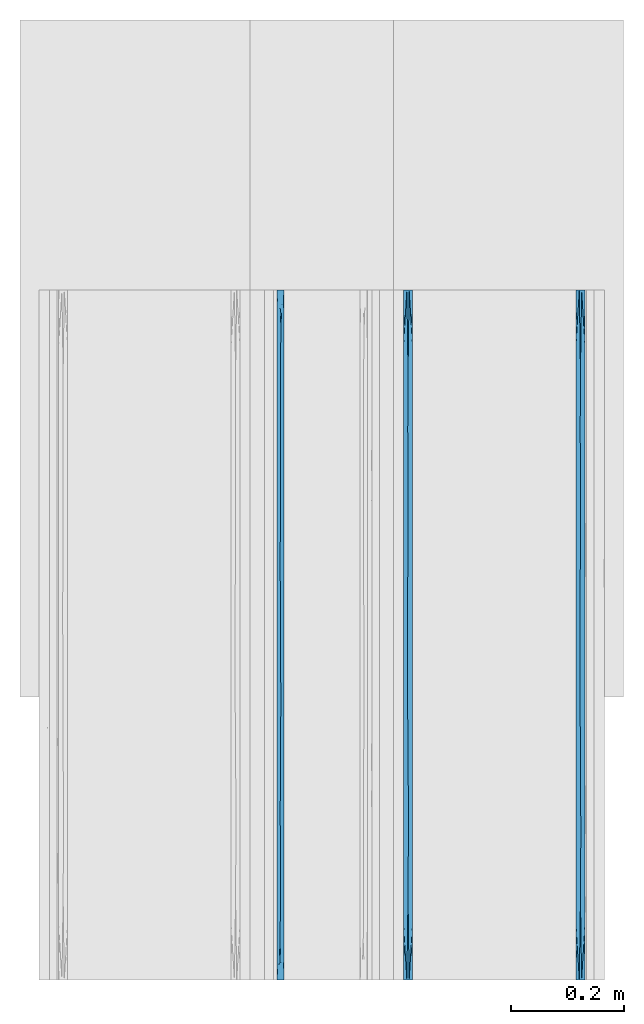
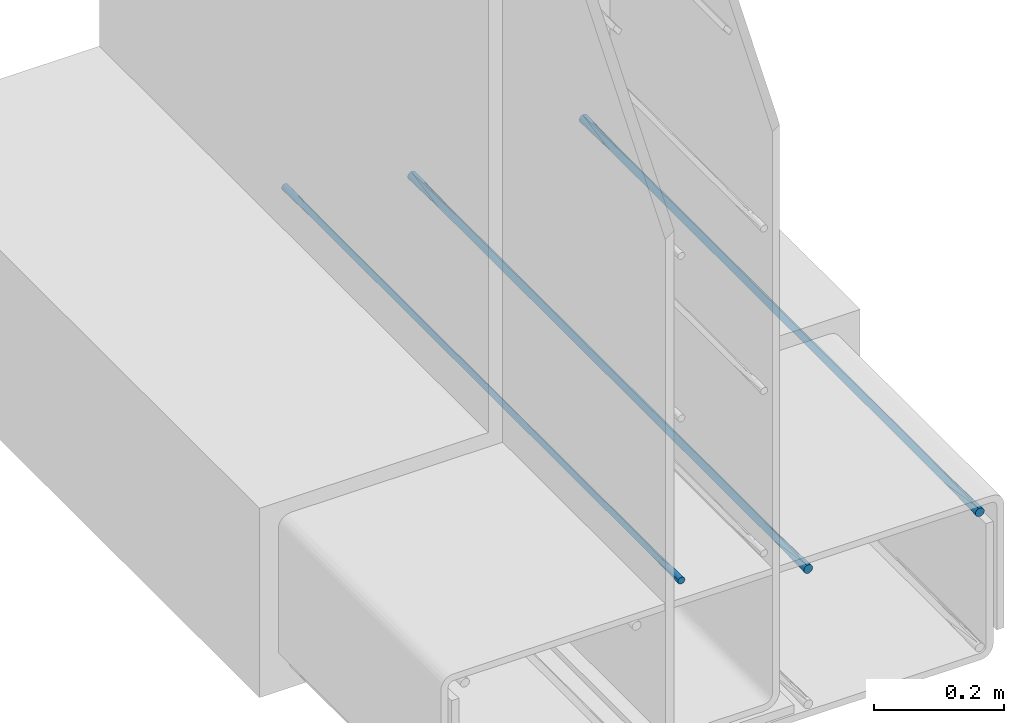
# One storey, part 7 of 10: 3 walls.
"""IFC2X3 building model written with IfcOpenShell, lengths in feet."""

from ifc_helpers import new_model, entity, si_unit, converted_unit, derived_unit, direction, frame, origin, place, context, subcontext, project, spatial, faceted_brep, material, type_object, element, save


model = new_model("IFC2X3")

# Units and contexts
model_context = context("Model", 3, precision=0.0001, world=origin(), true_north=direction((6.12303176911189e-17, 1.0)))
body_context = subcontext(model_context, "Body", "Model", "MODEL_VIEW")
ifc_project = project(units=[converted_unit("LENGTHUNIT", "FOOT", entity("IfcRatioMeasure", 0.3048), si_unit("LENGTHUNIT", "METRE"), dimensions=[1, 0, 0, 0, 0, 0, 0]), converted_unit("AREAUNIT", "SQUARE FOOT", entity("IfcRatioMeasure", 0.09290304), si_unit("AREAUNIT", "SQUARE_METRE"), dimensions=[2, 0, 0, 0, 0, 0, 0]), converted_unit("VOLUMEUNIT", "CUBIC FOOT", entity("IfcRatioMeasure", 0.028316846592), si_unit("VOLUMEUNIT", "CUBIC_METRE"), dimensions=[3, 0, 0, 0, 0, 0, 0]), converted_unit("PLANEANGLEUNIT", "DEGREE", entity("IfcRatioMeasure", 0.0174532925199433), si_unit("PLANEANGLEUNIT", "RADIAN"), dimensions=[0, 0, 0, 0, 0, 0, 0]), si_unit("MASSUNIT", "GRAM", prefix="KILO"), derived_unit("MASSDENSITYUNIT", [(si_unit("MASSUNIT", "GRAM", prefix="KILO"), 1), (si_unit("LENGTHUNIT", "METRE"), -3)]), si_unit("TIMEUNIT", "SECOND"), si_unit("FREQUENCYUNIT", "HERTZ"), si_unit("THERMODYNAMICTEMPERATUREUNIT", "DEGREE_CELSIUS"), derived_unit("THERMALTRANSMITTANCEUNIT", [(si_unit("MASSUNIT", "GRAM", prefix="KILO"), 1), (si_unit("THERMODYNAMICTEMPERATUREUNIT", "KELVIN"), -1), (si_unit("TIMEUNIT", "SECOND"), -3)]), derived_unit("VOLUMETRICFLOWRATEUNIT", [(si_unit("LENGTHUNIT", "METRE"), 3), (si_unit("TIMEUNIT", "SECOND"), -1)]), si_unit("ELECTRICCURRENTUNIT", "AMPERE"), si_unit("ELECTRICVOLTAGEUNIT", "VOLT"), si_unit("POWERUNIT", "WATT"), si_unit("FORCEUNIT", "NEWTON", prefix="KILO"), si_unit("ILLUMINANCEUNIT", "LUX"), si_unit("LUMINOUSFLUXUNIT", "LUMEN"), si_unit("LUMINOUSINTENSITYUNIT", "CANDELA"), derived_unit("USERDEFINED", [(si_unit("MASSUNIT", "GRAM", prefix="KILO"), -1), (si_unit("LENGTHUNIT", "METRE"), -2), (si_unit("TIMEUNIT", "SECOND"), 3), (si_unit("LUMINOUSFLUXUNIT", "LUMEN"), 1)]), derived_unit("LINEARVELOCITYUNIT", [(si_unit("LENGTHUNIT", "METRE"), 1), (si_unit("TIMEUNIT", "SECOND"), -1)]), si_unit("PRESSUREUNIT", "PASCAL"), derived_unit("USERDEFINED", [(si_unit("LENGTHUNIT", "METRE"), -2), (si_unit("MASSUNIT", "GRAM", prefix="KILO"), 1), (si_unit("TIMEUNIT", "SECOND"), -2)])], contexts=[model_context])

# Site, building, storey
site_placement = place(None, origin())
site = spatial("IfcSite", under=ifc_project, at=site_placement, CompositionType="ELEMENT")
building_placement = place(site_placement, origin())
building = spatial("IfcBuilding", under=site, at=building_placement, CompositionType="ELEMENT")
storey_placement = place(building_placement, frame((0.0, 0.0, 11.2604166666667)))
storey = spatial("IfcBuildingStorey", under=building, at=storey_placement, Name="2ND FLOOR", CompositionType="ELEMENT", Elevation=11.2604166666667)

# Walls
ifc_material_1 = material()
wall_type_1 = type_object("IfcWallType", Name="Generic Models 1", PredefinedType="NOTDEFINED", material=ifc_material_1)
wall_1_placement = place(storey_placement, frame((1430.15274703322, 0.249999999995827, 3.71232507741509), z_axis=(0.0, 0.0, 1.0), x_axis=(0.0, 1.0, 0.0)))
element("IfcWall", 1, at=wall_1_placement, inside=storey, type_object=wall_type_1, material=ifc_material_1, Name="Generic Models 83:Generic Models 1", ObjectType="Generic Models 83:Generic Models 1", context=body_context, shape_type="Brep", body=[
    faceted_brep([(4.0, -0.0130208333334849, 0.0034889217764551), (4.0, -0.00762742757342494, 0.0076274275732775), (4.0, -0.00348892177657945, 0.0130208333333464), (4.0, -0.000887348273863608, 0.0193015873671367), (4.0, 0.0, 0.0260416666666821), (4.0, -0.000887348273863608, 0.0327817459662274), (4.0, -0.00348892177657945, 0.0390625000000142), (4.0, -0.00762742757342494, 0.0444559057600777), (4.0, -0.0130208333334849, 0.0485944115568948), (4.0, -0.0193015873671811, 0.0511959850596142), (4.0, -0.0260416666667425, 0.0520833333333321), (4.0, -0.0327817459663038, 0.0511959850596071), (4.0, -0.0390625, 0.048594411556877), (4.0, -0.04445590576006, 0.0444559057600546), (4.0, -0.0485944115569055, 0.0390624999999858), (4.0, -0.0511959850596213, 0.0327817459661954), (4.0, -0.0520833333334849, 0.0260416666666501), (4.0, -0.0511959850596213, 0.0193015873671047), (4.0, -0.0485944115569055, 0.0130208333333179), (4.0, -0.04445590576006, 0.00762742757325441), (4.0, -0.0390625, 0.00348892177643734), (4.0, -0.0327817459663038, 0.000887348273717947), (4.0, -0.0260416666667425, 0.0), (4.0, -0.0193015873671811, 0.000887348273725053), (0.0, -0.0260416666667425, 0.0520833333333393), (0.0, -0.0193015873671811, 0.0511959850596213), (0.0, -0.0130208333334849, 0.0485944115569019), (0.0, -0.00762742757342494, 0.0444559057600848), (0.0, -0.00348892177657945, 0.0390625000000213), (0.0, -0.000887348273863608, 0.0327817459662345), (0.0, 0.0, 0.0260416666666892), (0.0, -0.000887348273863608, 0.0193015873671438), (0.0, -0.00348892177657945, 0.0130208333333535), (0.0, -0.00762742757342494, 0.00762742757328461), (0.0, -0.0130208333334849, 0.00348892177646221), (0.0, -0.0193015873671811, 0.000887348273732158), (0.0, -0.0260416666667425, 0.0), (0.0, -0.0327817459663038, 0.000887348273725053), (0.0, -0.0390625, 0.00348892177644444), (0.0, -0.04445590576006, 0.00762742757326151), (0.0, -0.0485944115569055, 0.013020833333325), (0.0, -0.0511959850596213, 0.0193015873671119), (0.0, -0.0520833333334849, 0.0260416666666572), (0.0, -0.0511959850596213, 0.0327817459662025), (0.0, -0.0485944115569055, 0.0390624999999929), (0.0, -0.04445590576006, 0.0444559057600618), (0.0, -0.0390625, 0.0485944115568842), (0.0, -0.0327817459663038, 0.0511959850596142), (3.67725138549306, 0.0, 0.0260416666666821), (0.32274862547415, -0.0520833333334849, 0.0260416666666572), (3.67725140296933, -0.0520833333334849, 0.0260416666666501), (3.51587705267192, -0.0260416670323593, 0.0), (2.87037982919681, -0.0260416666374113, 0.0), (2.52958652603254, -0.026227183774381, 6.60807051744428e-07), (2.70900554197223, 0.0, 0.0260416666666838), (2.70900552654688, -0.0520833333334849, 0.0260416666666536), (1.90213399266994, -0.0280271573828941, 7.58000453888741e-05), (1.5, 0.0, 0.0260416666666874), (1.74075971428411, 0.0, 0.0260416666666856), (2.0, 0.0, 0.0260416666666856), (1.58481828942483, -0.0281065462752395, 8.19926513742075e-05), (2.35450277098611, 0.0, 0.0260416666666838), (2.38625689346174, 0.0, 0.0260416666666874), (0.322748614506943, 0.0, 0.0260416666666892), (0.484122917594275, -0.0260416666644687, 0.0), (0.645497229013885, 0.0, 0.0260416666666874), (3.03175415647917, 0.0, 0.0260416666666838), (3.35450277098611, 0.0, 0.0260416666666838), (0.802626606099821, -0.0241210785507064, 7.09188132521632e-05), (1.0, 0.0, 0.0260416666666874), (1.12499999124347, -0.0246126796300814, 3.92360336185504e-05), (3.35450277749518, -0.0520833333334849, 0.0260416666666519), (2.2160433903769, -0.0283845183157609, 0.000105602028249052), (2.06350830404206, -0.0520833333334849, 0.0260416666666536), (2.00000002040847, -0.0520833333334849, 0.0260416666666536), (1.74075970701139, -0.0520833333334849, 0.0260416666666536), (3.19312844079874, -0.0276322430397613, 4.86201045735157e-05), (3.03175415202103, -0.0520833333334849, 0.0260416666666519), (0.70900554076862, -0.0520833333334849, 0.0260416666666554), (0.645497257127644, -0.0520833333334849, 0.0260416666666554), (1.41801108153724, -0.0520833333334849, 0.0260416666666554), (1.25, 0.0, 0.0260416666666874), (1.41801107183056, 0.0, 0.0260416666666874), (2.38625690107273, -0.0520833333334849, 0.0260416666666519), (2.06350830387292, 0.0, 0.0260416666666856), (1.50000002551058, -0.0520833333334849, 0.0260416666666519), (1.25000002806164, -0.0520833333334849, 0.0260416666666554), (1.06350832537467, -0.0520833333334849, 0.0260416666666554), (1.06350827744056, 0.0, 0.0260416666666874), (1.0000000306127, -0.0520833333334849, 0.0260416666666554), (2.35450279389352, -0.0520833333334849, 0.0260416666666519), (0.70900553591528, 0.0, 0.0260416666666874), (1.90213399388276, -0.0240561759483171, 0.0520075332877745), (3.51587705385881, -0.0260416658200029, 0.0520833333333339), (2.87037983051048, -0.0260416667615573, 0.0520833333333339), (2.52958652644354, -0.0258561495911636, 0.0520826725265131), (0.484122917756005, -0.0260416666742458, 0.0520833333333393), (3.19312844116365, -0.0244510900004116, 0.0520347132108157), (1.58481829017475, -0.023976787102356, 0.0520013406854787), (1.12499999099503, -0.0274706537484235, 0.052044097297248), (0.802626606321884, -0.0279622548152929, 0.0520124145176908), (2.2160433912069, -0.023698814974523, 0.051977731301184)], [[[0, 1, 2, 3, 4, 5, 6, 7, 8, 9, 10, 11, 12, 13, 14, 15, 16, 17, 18, 19, 20, 21, 22, 23]], [[24, 25, 26, 27, 28, 29, 30, 31, 32, 33, 34, 35, 36, 37, 38, 39, 40, 41, 42, 43, 44, 45, 46, 47]], [[2, 48, 3]], [[49, 42, 41]], [[17, 16, 50]], [[20, 50, 21]], [[50, 51, 21]], [[40, 49, 41]], [[52, 53, 54]], [[52, 55, 53]], [[50, 19, 18]], [[56, 57, 58, 59]], [[38, 37, 49]], [[60, 57, 56]], [[0, 48, 1]], [[53, 61, 62, 54]], [[63, 32, 31]], [[64, 63, 65]], [[52, 54, 66]], [[48, 51, 67]], [[68, 69, 70]], [[23, 22, 51]], [[35, 64, 36]], [[2, 1, 48]], [[18, 17, 50]], [[19, 50, 20]], [[50, 71, 51]], [[56, 72, 73]], [[56, 73, 74, 75]], [[67, 51, 76]], [[55, 52, 77]], [[64, 78, 79, 49]], [[39, 38, 49]], [[0, 23, 48]], [[48, 23, 51]], [[60, 80, 70]], [[64, 65, 68]], [[37, 36, 64]], [[51, 22, 21]], [[60, 81, 82, 57]], [[40, 39, 49]], [[32, 63, 33]], [[77, 52, 76]], [[66, 67, 76]], [[34, 33, 63]], [[71, 77, 76]], [[35, 63, 64]], [[34, 63, 35]], [[48, 4, 3]], [[31, 30, 63]], [[53, 72, 61]], [[53, 83, 72]], [[64, 49, 37]], [[56, 75, 60]], [[72, 59, 84, 61]], [[60, 75, 85, 80]], [[70, 81, 60]], [[64, 68, 78]], [[70, 80, 86, 87]], [[70, 69, 88, 81]], [[68, 87, 89, 78]], [[72, 56, 59]], [[83, 53, 55]], [[72, 83, 90, 73]], [[76, 52, 66]], [[71, 76, 51]], [[68, 65, 91, 69]], [[87, 68, 70]], [[92, 84, 59, 58]], [[14, 50, 15]], [[8, 48, 9]], [[48, 93, 9]], [[28, 63, 29]], [[94, 95, 55]], [[44, 43, 49]], [[94, 54, 95]], [[47, 96, 24]], [[11, 10, 93]], [[5, 4, 48]], [[63, 30, 29]], [[66, 94, 97]], [[98, 85, 92]], [[12, 50, 13]], [[98, 86, 80, 85]], [[89, 99, 100]], [[49, 79, 96]], [[96, 91, 65, 63]], [[7, 48, 8]], [[48, 6, 5]], [[14, 13, 50]], [[48, 7, 6]], [[50, 93, 71]], [[48, 67, 93]], [[92, 101, 84]], [[12, 11, 50]], [[66, 54, 94]], [[95, 90, 83, 55]], [[27, 26, 63]], [[50, 11, 93]], [[96, 79, 100]], [[98, 82, 99]], [[92, 85, 75, 74]], [[24, 96, 25]], [[93, 10, 9]], [[97, 77, 71]], [[28, 27, 63]], [[44, 49, 45]], [[50, 16, 15]], [[43, 42, 49]], [[93, 97, 71]], [[46, 45, 49]], [[67, 66, 97]], [[47, 49, 96]], [[46, 49, 47]], [[26, 25, 63]], [[95, 101, 90]], [[95, 62, 101]], [[96, 63, 25]], [[92, 58, 98]], [[101, 74, 73, 90]], [[98, 58, 57, 82]], [[99, 86, 98]], [[96, 100, 91]], [[99, 82, 81, 88]], [[99, 89, 87, 86]], [[100, 88, 69, 91]], [[101, 92, 74]], [[94, 55, 77]], [[62, 95, 54]], [[101, 62, 61, 84]], [[97, 94, 77]], [[67, 97, 93]], [[100, 79, 78, 89]], [[88, 100, 99]]]),
])
wall_type_2 = type_object("IfcWallType", Name="Generic Models 1", PredefinedType="NOTDEFINED", material=ifc_material_1)
wall_2_placement = place(storey_placement, frame((1431.15274703322, 0.249999999995824, 3.71232507741508), z_axis=(0.0, 0.0, 1.0), x_axis=(0.0, 1.0, 0.0)))
element("IfcWall", 2, at=wall_2_placement, inside=storey, type_object=wall_type_2, material=ifc_material_1, Name="Generic Models 93:Generic Models 1", ObjectType="Generic Models 93:Generic Models 1", context=body_context, shape_type="Brep", body=[
    faceted_brep([(4.0, -0.0130208333334849, 0.0034889217764551), (4.0, -0.00762742757342494, 0.0076274275732775), (4.0, -0.00348892177657945, 0.0130208333333464), (4.0, -0.000887348273863608, 0.0193015873671367), (4.0, 0.0, 0.0260416666666821), (4.0, -0.000887348273863608, 0.0327817459662274), (4.0, -0.00348892177657945, 0.0390625000000142), (4.0, -0.00762742757342494, 0.0444559057600777), (4.0, -0.0130208333334849, 0.0485944115568948), (4.0, -0.0193015873671811, 0.0511959850596142), (4.0, -0.0260416666667425, 0.0520833333333321), (4.0, -0.0327817459663038, 0.0511959850596071), (4.0, -0.0390625, 0.048594411556877), (4.0, -0.04445590576006, 0.0444559057600546), (4.0, -0.0485944115569055, 0.0390624999999858), (4.0, -0.0511959850596213, 0.0327817459661954), (4.0, -0.0520833333334849, 0.0260416666666501), (4.0, -0.0511959850596213, 0.0193015873671047), (4.0, -0.0485944115569055, 0.0130208333333179), (4.0, -0.04445590576006, 0.00762742757325441), (4.0, -0.0390625, 0.00348892177643734), (4.0, -0.0327817459663038, 0.000887348273717947), (4.0, -0.0260416666667425, 0.0), (4.0, -0.0193015873671811, 0.000887348273725053), (0.0, -0.0260416666667425, 0.0520833333333393), (0.0, -0.0193015873671811, 0.0511959850596213), (0.0, -0.0130208333334849, 0.0485944115569019), (0.0, -0.00762742757342494, 0.0444559057600848), (0.0, -0.00348892177657945, 0.0390625000000213), (0.0, -0.000887348273863608, 0.0327817459662345), (0.0, 0.0, 0.0260416666666892), (0.0, -0.000887348273863608, 0.0193015873671438), (0.0, -0.00348892177657945, 0.0130208333333535), (0.0, -0.00762742757342494, 0.00762742757328461), (0.0, -0.0130208333334849, 0.00348892177646221), (0.0, -0.0193015873671811, 0.000887348273732158), (0.0, -0.0260416666667425, 0.0), (0.0, -0.0327817459663038, 0.000887348273725053), (0.0, -0.0390625, 0.00348892177644444), (0.0, -0.04445590576006, 0.00762742757326151), (0.0, -0.0485944115569055, 0.013020833333325), (0.0, -0.0511959850596213, 0.0193015873671119), (0.0, -0.0520833333334849, 0.0260416666666572), (0.0, -0.0511959850596213, 0.0327817459662025), (0.0, -0.0485944115569055, 0.0390624999999929), (0.0, -0.04445590576006, 0.0444559057600618), (0.0, -0.0390625, 0.0485944115568842), (0.0, -0.0327817459663038, 0.0511959850596142), (3.67725138549306, 0.0, 0.0260416666666838), (0.32274862547415, -0.0520833333334849, 0.0260416666666572), (3.67725140296933, -0.0520833333334849, 0.0260416666666501), (3.51587705267192, -0.0260416670323593, 0.0), (2.87037982919681, -0.0260416666374113, 0.0), (2.52958652603254, -0.026227183774381, 6.60807051744428e-07), (2.70900554197223, 0.0, 0.0260416666666838), (2.70900552654688, -0.0520833333334849, 0.0260416666666519), (1.90213399266994, -0.0280271573828941, 7.58000453888741e-05), (1.5, 0.0, 0.0260416666666874), (1.74075971428411, 0.0, 0.0260416666666856), (2.0, 0.0, 0.0260416666666856), (1.58481828942483, -0.0281065462752395, 8.19926513742075e-05), (2.35450277098611, 0.0, 0.0260416666666856), (2.38625689346174, 0.0, 0.0260416666666856), (0.322748614506943, 0.0, 0.0260416666666874), (0.484122917594275, -0.0260416666644687, 0.0), (0.645497229013885, 0.0, 0.0260416666666874), (3.03175415647917, 0.0, 0.0260416666666838), (3.35450277098611, 0.0, 0.0260416666666821), (0.802626606099821, -0.0241210785507064, 7.09188132521632e-05), (1.0, 0.0, 0.0260416666666874), (1.12499999124347, -0.0246126796300814, 3.92360336185504e-05), (3.35450277749518, -0.0520833333334849, 0.0260416666666501), (2.2160433903769, -0.0283845183157609, 0.000105602028249052), (2.06350830404206, -0.0520833333334849, 0.0260416666666519), (2.00000002040847, -0.0520833333334849, 0.0260416666666536), (1.74075970701139, -0.0520833333334849, 0.0260416666666554), (3.19312844079874, -0.0276322430397613, 4.86201045735157e-05), (3.03175415202103, -0.0520833333334849, 0.0260416666666519), (0.70900554076862, -0.0520833333334849, 0.0260416666666554), (0.645497257127644, -0.0520833333334849, 0.0260416666666554), (1.41801108153724, -0.0520833333334849, 0.0260416666666554), (1.25, 0.0, 0.0260416666666874), (1.41801107183056, 0.0, 0.0260416666666874), (2.38625690107273, -0.0520833333334849, 0.0260416666666536), (2.06350830387292, 0.0, 0.0260416666666838), (1.50000002551058, -0.0520833333334849, 0.0260416666666536), (1.25000002806164, -0.0520833333334849, 0.0260416666666554), (1.06350832537467, -0.0520833333334849, 0.0260416666666554), (1.06350827744056, 0.0, 0.0260416666666874), (1.0000000306127, -0.0520833333334849, 0.0260416666666554), (2.35450279389352, -0.0520833333334849, 0.0260416666666519), (0.70900553591528, 0.0, 0.0260416666666874), (1.90213399388276, -0.0240561759483171, 0.0520075332877745), (3.51587705385881, -0.0260416658200029, 0.0520833333333339), (2.87037983051048, -0.0260416667615573, 0.0520833333333339), (2.52958652644354, -0.0258561495911636, 0.0520826725265131), (0.484122917756005, -0.0260416666742458, 0.0520833333333393), (3.19312844116365, -0.0244510900004116, 0.0520347132108157), (1.58481829017475, -0.023976787102356, 0.0520013406854787), (1.12499999099503, -0.0274706537484235, 0.052044097297248), (0.802626606321884, -0.0279622548152929, 0.0520124145176908), (2.2160433912069, -0.023698814974523, 0.051977731301184)], [[[0, 1, 2, 3, 4, 5, 6, 7, 8, 9, 10, 11, 12, 13, 14, 15, 16, 17, 18, 19, 20, 21, 22, 23]], [[24, 25, 26, 27, 28, 29, 30, 31, 32, 33, 34, 35, 36, 37, 38, 39, 40, 41, 42, 43, 44, 45, 46, 47]], [[2, 48, 3]], [[49, 42, 41]], [[17, 16, 50]], [[20, 50, 21]], [[50, 51, 21]], [[40, 49, 41]], [[52, 53, 54]], [[52, 55, 53]], [[50, 19, 18]], [[56, 57, 58, 59]], [[38, 37, 49]], [[60, 57, 56]], [[0, 48, 1]], [[53, 61, 62, 54]], [[63, 32, 31]], [[64, 63, 65]], [[52, 54, 66]], [[48, 51, 67]], [[68, 69, 70]], [[23, 22, 51]], [[35, 64, 36]], [[2, 1, 48]], [[18, 17, 50]], [[19, 50, 20]], [[50, 71, 51]], [[56, 72, 73]], [[56, 73, 74, 75]], [[67, 51, 76]], [[55, 52, 77]], [[64, 78, 79, 49]], [[39, 38, 49]], [[0, 23, 48]], [[48, 23, 51]], [[60, 80, 70]], [[64, 65, 68]], [[37, 36, 64]], [[51, 22, 21]], [[60, 81, 82, 57]], [[40, 39, 49]], [[32, 63, 33]], [[77, 52, 76]], [[66, 67, 76]], [[34, 33, 63]], [[71, 77, 76]], [[35, 63, 64]], [[34, 63, 35]], [[48, 4, 3]], [[31, 30, 63]], [[53, 72, 61]], [[53, 83, 72]], [[64, 49, 37]], [[56, 75, 60]], [[72, 59, 84, 61]], [[60, 75, 85, 80]], [[70, 81, 60]], [[64, 68, 78]], [[70, 80, 86, 87]], [[70, 69, 88, 81]], [[68, 87, 89, 78]], [[72, 56, 59]], [[83, 53, 55]], [[72, 83, 90, 73]], [[76, 52, 66]], [[71, 76, 51]], [[68, 65, 91, 69]], [[87, 68, 70]], [[92, 84, 59, 58]], [[14, 50, 15]], [[8, 48, 9]], [[48, 93, 9]], [[28, 63, 29]], [[94, 95, 55]], [[44, 43, 49]], [[94, 54, 95]], [[47, 96, 24]], [[11, 10, 93]], [[5, 4, 48]], [[63, 30, 29]], [[66, 94, 97]], [[98, 85, 92]], [[12, 50, 13]], [[98, 86, 80, 85]], [[89, 99, 100]], [[49, 79, 96]], [[96, 91, 65, 63]], [[7, 48, 8]], [[48, 6, 5]], [[14, 13, 50]], [[48, 7, 6]], [[50, 93, 71]], [[48, 67, 93]], [[92, 101, 84]], [[12, 11, 50]], [[66, 54, 94]], [[95, 90, 83, 55]], [[27, 26, 63]], [[50, 11, 93]], [[96, 79, 100]], [[98, 82, 99]], [[92, 85, 75, 74]], [[24, 96, 25]], [[93, 10, 9]], [[97, 77, 71]], [[28, 27, 63]], [[44, 49, 45]], [[50, 16, 15]], [[43, 42, 49]], [[93, 97, 71]], [[46, 45, 49]], [[67, 66, 97]], [[47, 49, 96]], [[46, 49, 47]], [[26, 25, 63]], [[95, 101, 90]], [[95, 62, 101]], [[96, 63, 25]], [[92, 58, 98]], [[101, 74, 73, 90]], [[98, 58, 57, 82]], [[99, 86, 98]], [[96, 100, 91]], [[99, 82, 81, 88]], [[99, 89, 87, 86]], [[100, 88, 69, 91]], [[101, 92, 74]], [[94, 55, 77]], [[62, 95, 54]], [[101, 62, 61, 84]], [[97, 94, 77]], [[67, 97, 93]], [[100, 79, 78, 89]], [[88, 100, 99]]]),
])
ifc_material_2 = material()
wall_type_3 = type_object("IfcWallType", Name="Generic Models 1", PredefinedType="NOTDEFINED", material=ifc_material_2)
wall_3_placement = place(storey_placement, frame((1429.41837203322, 0.249999999995826, 3.90503341074841), z_axis=(0.0, 0.0, 1.0), x_axis=(0.0, 1.0, 0.0)))
element("IfcWall", 3, at=wall_3_placement, inside=storey, type_object=wall_type_3, material=ifc_material_2, Name="Generic Models 222:Generic Models 1", ObjectType="Generic Models 222:Generic Models 1", context=body_context, shape_type="Brep", body=[
    faceted_brep([(4.0, -0.0262253967728157, 0.0409567880476889), (4.0, -0.03125, 0.0388755292455105), (4.0, -0.0355647246078661, 0.0355647246080544), (4.0, -0.038875529245388, 0.03125), (4.0, -0.0409567880476516, 0.0262253967729702), (4.0, -0.0416666666665151, 0.0208333333333339), (4.0, -0.0409567880476516, 0.0154412698936977), (4.0, -0.038875529245388, 0.0104166666666679), (4.0, -0.0355647246078661, 0.00610194205861347), (4.0, -0.03125, 0.00279113742115733), (4.0, -0.0262253967728157, 0.000709878618978976), (4.0, -0.0208333333332575, 0.0), (4.0, -0.0154412698936994, 0.000709878618978976), (4.0, -0.0104166666665151, 0.00279113742115733), (4.0, -0.006101942058649, 0.00610194205861347), (4.0, -0.00279113742112713, 0.0104166666666679), (4.0, -0.000709878618863513, 0.0154412698936977), (4.0, 0.0, 0.0208333333333339), (4.0, -0.000709878618863513, 0.0262253967729702), (4.0, -0.00279113742112713, 0.03125), (4.0, -0.006101942058649, 0.0355647246080544), (4.0, -0.0104166666665151, 0.0388755292455105), (4.0, -0.0154412698936994, 0.0409567880476889), (4.0, -0.0208333333332575, 0.0416666666666679), (0.0, -0.0262253967728157, 0.000709878618986082), (0.0, -0.03125, 0.00279113742116444), (0.0, -0.0355647246078661, 0.00610194205862058), (0.0, -0.038875529245388, 0.010416666666675), (0.0, -0.0409567880476516, 0.0154412698937048), (0.0, -0.0416666666665151, 0.020833333333341), (0.0, -0.0409567880476516, 0.0262253967729773), (0.0, -0.038875529245388, 0.0312500000000071), (0.0, -0.0355647246078661, 0.0355647246080615), (0.0, -0.03125, 0.0388755292455176), (0.0, -0.0262253967728157, 0.040956788047696), (0.0, -0.0208333333332575, 0.041666666666675), (0.0, -0.0154412698936994, 0.040956788047696), (0.0, -0.0104166666665151, 0.0388755292455176), (0.0, -0.006101942058649, 0.0355647246080615), (0.0, -0.00279113742112713, 0.0312500000000071), (0.0, -0.000709878618863513, 0.0262253967729773), (0.0, 0.0, 0.020833333333341), (0.0, -0.000709878618863513, 0.0154412698937048), (0.0, -0.00279113742112713, 0.010416666666675), (0.0, -0.006101942058649, 0.00610194205862058), (0.0, -0.0104166666665151, 0.00279113742116444), (0.0, -0.0154412698936994, 0.000709878618986082), (0.0, -0.0208333333332575, 0.0), (2.14388402114763, -0.0200322252712795, 1.54082770116304e-05), (1.8749999873482, -0.0201164472750861, 1.23378682452824e-05), (2.0, 0.0, 0.0208333333333375), (0.2209945797568, -0.0235526290068719, 0.000178232055045413), (3.78349365025041, -0.0181140376355415, 0.000178232058184236), (0.288675181168509, -0.0416666666665151, 0.020833333333341), (2.55662427510468, -0.0416666666667425, 0.0208333333333375), (2.39350545093993, -0.0230795128859427, 0.000121441696036229), (2.72964779378728, -0.0208333333494011, 0.0), (3.71132487914723, -0.0416666666665151, 0.0208333333333339), (0.959427115258349, -0.0225483860315308, 7.07137486237741e-05), (0.78867513369125, 0.0, 0.0208333333333393), (0.845299480274044, 0.0, 0.0208333333333393), (1.0, 0.0, 0.020833333333341), (1.05662434259908, 0.0, 0.0208333333333393), (1.25, 0.0, 0.0208333333333375), (1.75, 0.0, 0.0208333333333375), (1.62498580610317, -0.0185830665252524, 0.00012188536196156), (3.71132486630875, 0.0, 0.0208333333333339), (0.28867513369125, 0.0, 0.020833333333341), (0.577350267382501, 0.0, 0.0208333333333393), (0.711324858555642, -0.0208333333287101, 0.0), (0.44198915950752, -0.0208333333268911, 0.0), (3.13397456595189, 0.0, 0.0208333333333357), (3.42264969964314, 0.0, 0.0208333333333339), (3.27831213705374, -0.0208333333389419, 0.0), (2.98963700310718, -0.0208333333653172, 0.0), (2.63397456595189, 0.0, 0.0208333333333357), (2.84529943226064, 0.0, 0.0208333333333357), (3.56698727175129, -0.0208333335056068, 0.0), (3.42264975829447, -0.0416666666665151, 0.0208333333333339), (3.1339746374417, -0.0416666666665151, 0.0208333333333339), (2.84529945627319, -0.0416666666662877, 0.0208333333333339), (2.6339745906388, -0.0416666666665151, 0.0208333333333375), (0.845299486431061, -0.0416666666665151, 0.0208333333333393), (0.788675136453734, -0.0416666666665151, 0.0208333333333375), (0.577350302021276, -0.0416666666665151, 0.020833333333341), (1.97927407112088, 0.0, 0.0208333333333375), (1.97927403339915, -0.0416666666665151, 0.0208333333333375), (2.26794915425192, -0.0416666666662877, 0.0208333333333375), (2.21132486354627, -0.0416666666665151, 0.0208333333333375), (2.0, -0.0416666666665151, 0.0208333333333375), (2.21132486630875, 0.0, 0.0208333333333375), (2.26794921266759, 0.0, 0.0208333333333375), (2.42264969964314, 0.0, 0.0208333333333375), (2.55662432324038, 0.0, 0.0208333333333375), (1.75, -0.0416666666665151, 0.0208333333333375), (1.69059891254638, -0.0416666666665151, 0.0208333333333375), (1.47927402585968, -0.0416666666665151, 0.0208333333333375), (1.3749999905963, -0.0202049447002537, 9.47909105875056e-06), (2.42264972709253, -0.0416666666665151, 0.0208333333333375), (1.26794920492411, 0.0, 0.0208333333333375), (1.47927406724915, 0.0, 0.0208333333333375), (1.5, 0.0, 0.0208333333333375), (1.26794919948872, -0.0416666666665151, 0.0208333333333375), (1.25, -0.0416666666665151, 0.0208333333333375), (1.05662437311776, -0.0416666666665151, 0.0208333333333393), (1.0, -0.0416666666667425, 0.020833333333341), (1.5, -0.0416666666665151, 0.0208333333333375), (1.69059892957418, 0.0, 0.0208333333333393), (2.14388402115656, -0.0216344413906882, 0.0416512583898374), (1.87499998744159, -0.0215502193923385, 0.0416543287983959), (0.220994579714599, -0.0181140376603253, 0.0414884346117432), (3.78349365012031, -0.0235526293449766, 0.0414884345671229), (2.3935054510086, -0.0185871537623825, 0.0415452249686457), (2.72964779341247, -0.0208333333278006, 0.0416666666666696), (0.959427115233259, -0.0191182806272536, 0.0415959529174241), (1.62498580618022, -0.023083600129894, 0.0415447813059462), (0.711324858513196, -0.0208333333348492, 0.0416666666666732), (0.441989159426871, -0.0208333333353039, 0.0416666666666732), (3.27831213726184, -0.0208333333314386, 0.0416666666666679), (2.9896370028857, -0.020833333322571, 0.0416666666666696), (3.56698727186825, -0.0208333332750499, 0.0416666666666679), (1.37499999066007, -0.0214617219517095, 0.0416571875760585)], [[[0, 1, 2, 3, 4, 5, 6, 7, 8, 9, 10, 11, 12, 13, 14, 15, 16, 17, 18, 19, 20, 21, 22, 23]], [[24, 25, 26, 27, 28, 29, 30, 31, 32, 33, 34, 35, 36, 37, 38, 39, 40, 41, 42, 43, 44, 45, 46, 47]], [[48, 49, 50]], [[24, 47, 51]], [[52, 9, 8]], [[27, 53, 28]], [[54, 55, 56]], [[51, 25, 24]], [[57, 7, 6]], [[57, 8, 7]], [[52, 13, 12]], [[6, 5, 57]], [[29, 28, 53]], [[58, 59, 60, 61, 62, 63]], [[64, 49, 65]], [[52, 14, 13]], [[66, 17, 16]], [[42, 41, 67]], [[42, 67, 43]], [[68, 59, 69, 70, 67]], [[71, 72, 73, 74, 56, 75, 76]], [[66, 77, 72]], [[78, 79, 80, 81, 54, 56, 74, 73]], [[69, 82, 83, 84, 53, 70]], [[78, 77, 57]], [[77, 52, 57]], [[49, 64, 85, 50]], [[48, 86, 49]], [[15, 66, 16]], [[47, 46, 51]], [[14, 52, 15]], [[70, 53, 51]], [[82, 69, 58]], [[69, 59, 58]], [[51, 26, 25]], [[44, 43, 67]], [[10, 52, 11]], [[45, 51, 46]], [[67, 70, 51]], [[44, 51, 45]], [[51, 27, 26]], [[51, 44, 67]], [[57, 52, 8]], [[48, 87, 88, 89, 86]], [[9, 52, 10]], [[55, 90, 91, 92, 93, 75]], [[53, 27, 51]], [[49, 86, 94, 95]], [[90, 55, 48]], [[73, 72, 77]], [[12, 11, 52]], [[73, 77, 78]], [[77, 66, 52]], [[66, 15, 52]], [[87, 48, 55]], [[55, 75, 56]], [[65, 96, 97]], [[55, 54, 98, 87]], [[97, 63, 99, 100, 101]], [[58, 102, 103, 104, 105, 82]], [[63, 97, 58]], [[97, 101, 65]], [[65, 95, 106, 96]], [[65, 101, 107, 64]], [[95, 65, 49]], [[102, 58, 97]], [[96, 102, 97]], [[48, 50, 90]], [[108, 109, 89]], [[36, 35, 110]], [[111, 21, 20]], [[39, 67, 40]], [[93, 112, 113]], [[110, 37, 36]], [[66, 19, 18]], [[66, 20, 19]], [[111, 1, 0]], [[18, 17, 66]], [[41, 40, 67]], [[114, 83, 82, 105, 104, 103]], [[94, 109, 115]], [[111, 2, 1]], [[57, 5, 4]], [[30, 29, 53]], [[30, 53, 31]], [[84, 83, 116, 117, 53]], [[79, 78, 118, 119, 113, 81, 80]], [[116, 83, 114]], [[72, 71, 76, 75, 93, 113, 119, 118]], [[116, 60, 59, 68, 67, 117]], [[72, 118, 120, 66]], [[120, 111, 66]], [[109, 94, 86, 89]], [[108, 85, 109]], [[3, 57, 4]], [[2, 111, 3]], [[34, 110, 35]], [[117, 67, 110]], [[60, 116, 114]], [[57, 120, 118, 78]], [[110, 38, 37]], [[32, 31, 53]], [[22, 111, 23]], [[33, 110, 34]], [[53, 117, 110]], [[32, 110, 33]], [[110, 39, 38]], [[110, 32, 53]], [[66, 111, 20]], [[108, 91, 90, 50, 85]], [[21, 111, 22]], [[112, 88, 87, 98, 54, 81]], [[67, 39, 110]], [[109, 85, 64, 107]], [[88, 112, 108]], [[0, 23, 111]], [[120, 57, 111]], [[57, 3, 111]], [[91, 108, 112]], [[112, 81, 113]], [[115, 100, 121]], [[112, 93, 92, 91]], [[121, 103, 102, 96, 106]], [[114, 99, 63, 62, 61, 60]], [[103, 121, 114]], [[121, 106, 115]], [[115, 107, 101, 100]], [[115, 106, 95, 94]], [[107, 115, 109]], [[99, 114, 121]], [[100, 99, 121]], [[108, 89, 88]]]),
])

save(model, "model.ifc")
